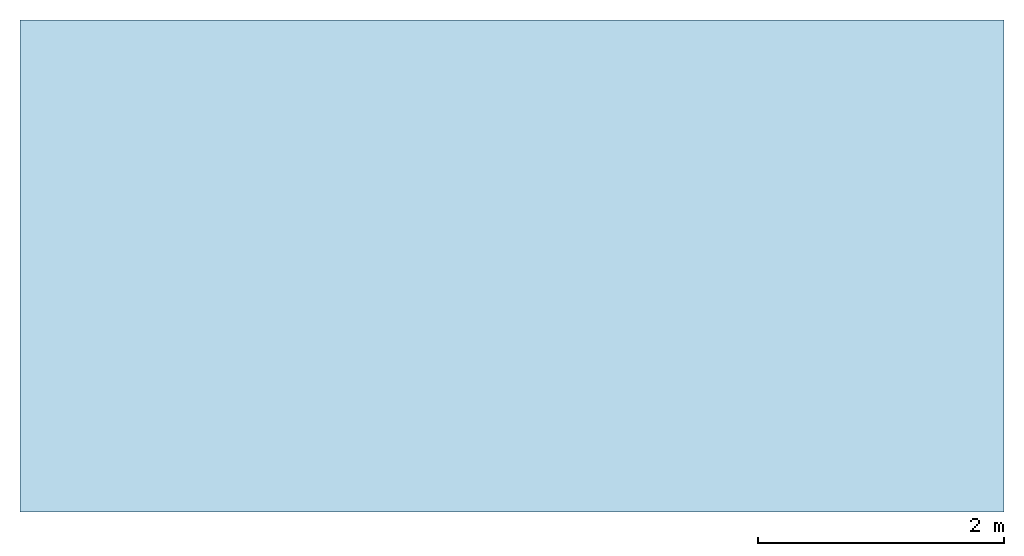
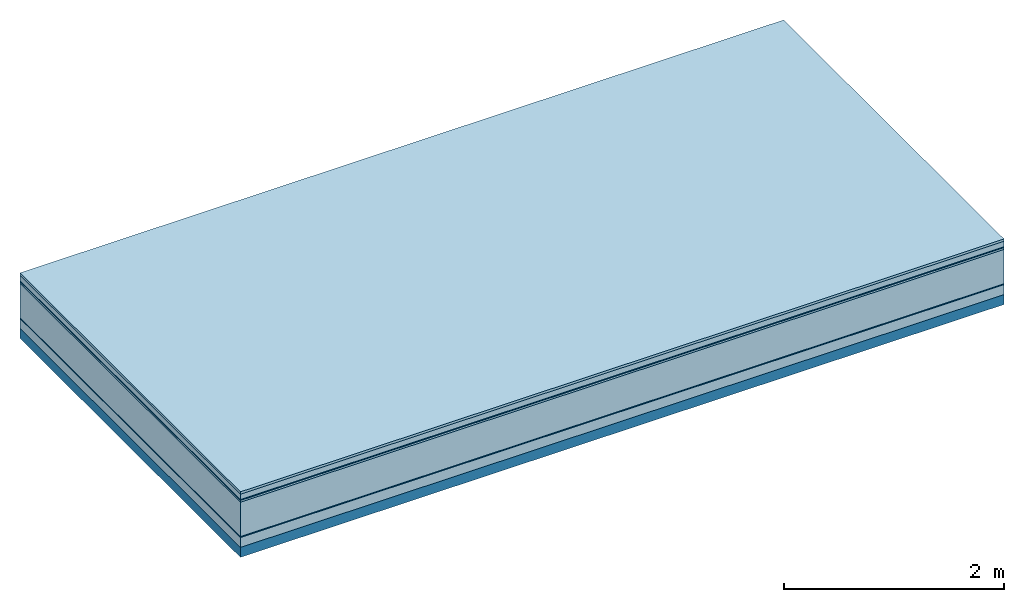
# One storey: 7 plates, 1 member, 1 element without a shape of its own.
"""IFC4 building model written with IfcOpenShell, lengths in metres."""

from ifc_helpers import new_model, si_unit, derived_unit, direction, frame, frame_2d, origin, origin_with_axes, place, context, project, spatial, rectangle, extrude, material, layer, layer_set, type_object, element, aggregate, save


model = new_model("IFC4")

# Units and contexts
plan_context = context("Plan", 3, precision=1e-05, world=origin(), true_north=direction((0.0, 1.0)))
model_context = context("Model", 3, precision=1e-05, world=origin(), true_north=direction((0.0, 1.0)))
ifc_project = project(units=[si_unit("LENGTHUNIT", "METRE"), derived_unit("SOUNDPRESSUREUNIT", [(si_unit("PRESSUREUNIT", "PASCAL", prefix="MICRO"), 0)]), si_unit("ENERGYUNIT", "JOULE", prefix="MEGA"), si_unit("MASSUNIT", "GRAM", prefix="KILO"), derived_unit("THERMALTRANSMITTANCEUNIT", [(si_unit("POWERUNIT", "WATT"), 1), (si_unit("AREAUNIT", "SQUARE_METRE"), -1), (si_unit("THERMODYNAMICTEMPERATUREUNIT", "KELVIN"), -1)]), derived_unit("AREADENSITYUNIT", [(si_unit("MASSUNIT", "GRAM", prefix="KILO"), 1), (si_unit("AREAUNIT", "SQUARE_METRE"), -1)]), derived_unit("USERDEFINED", [(si_unit("ENERGYUNIT", "JOULE", prefix="MEGA"), 1), (si_unit("AREAUNIT", "SQUARE_METRE"), -1)])], contexts=[plan_context, model_context])

# Site, building, storey
site = spatial("IfcSite", under=ifc_project)
building_placement = place(None, origin())
building = spatial("IfcBuilding", under=site, at=building_placement)
storey_placement = place(building_placement, origin())
storey = spatial("IfcBuildingStorey", under=building, at=storey_placement)

# Slab, member, plates
ifc_material_1 = material(Category="07.009")
ifc_layer_1 = layer(ifc_material_1, 0.026, Name="Use and protection layer 3")
ifc_material_2 = material(Category="07.011")
ifc_layer_2 = layer(ifc_material_2, 0.06, Name="Use and protection layer 2")
ifc_material_3 = material(Name="Protective layer + Fire protection cover RF1", Category="09.007")
ifc_layer_3 = layer(ifc_material_3, 0.01, Name="Use and protection layer 1")
ifc_material_4 = material(Name="Bituminous", Category="09.003")
ifc_layer_4 = layer(ifc_material_4, 0.02, Name="Seal")
ifc_material_5 = material(Name="Mineral wool", Category="10.008")
ifc_layer_5 = layer(ifc_material_5, 0.38, Name="Exterior insulation layer 1")
ifc_material_6 = material(Name="Vapor-permeable barrier", Category="09.006")
ifc_layer_6 = layer(ifc_material_6, 0.01, Name="layer / temporary roof")
ifc_material_7 = material(Category="01.002")
ifc_layer_7 = layer(ifc_material_7, 0.11, Name="above 1st layer")
ifc_material_8 = material(Name="Rigid, of the art")
ifc_layer_8 = layer(ifc_material_8, 0.0, Name="Bond")
ifc_layer_9 = layer(None, 0.11, Name="Support")
ifc_layer_set = layer_set([ifc_layer_1, ifc_layer_2, ifc_layer_3, ifc_layer_4, ifc_layer_5, ifc_layer_6, ifc_layer_7, ifc_layer_8, ifc_layer_9])
slab_type = type_object("IfcSlabType", Name="F0082", PredefinedType="NOTDEFINED", material=ifc_layer_set)
slab_placement = place(None, frame((0.0, 0.0, 0.0), z_axis=(0.0, 0.0, -1.0), x_axis=(1.0, 0.0, 0.0)))
slab = element("IfcSlab", 1, at=slab_placement, inside=storey, type_object=slab_type, material=ifc_layer_set, Name="Slab #1")
ifc_material_9 = material(Name="Solid timber panel")
member_placement = place(slab_placement, origin())
member = element("IfcMember", 2, at=member_placement, material=ifc_material_9, Name="Support", context=plan_context, shape_type="SweptSolid", body=[
    extrude(rectangle(XDim=1.0, YDim=0.11, at=frame_2d((0.5, 0.055), x_axis=(1.0, 0.0))), frame((0.0, 4.0, 0.616), z_axis=(0.0, -1.0, 0.0), x_axis=(1.0, 0.0, 0.0)), (0.0, 0.0, 1.0), 4.0),
    extrude(rectangle(XDim=1.0, YDim=0.11, at=frame_2d((0.5, 0.055), x_axis=(1.0, 0.0))), frame((1.0, 4.0, 0.616), z_axis=(0.0, -1.0, 0.0), x_axis=(1.0, 0.0, 0.0)), (0.0, 0.0, 1.0), 4.0),
    extrude(rectangle(XDim=1.0, YDim=0.11, at=frame_2d((0.5, 0.055), x_axis=(1.0, 0.0))), frame((2.0, 4.0, 0.616), z_axis=(0.0, -1.0, 0.0), x_axis=(1.0, 0.0, 0.0)), (0.0, 0.0, 1.0), 4.0),
    extrude(rectangle(XDim=1.0, YDim=0.11, at=frame_2d((0.5, 0.055), x_axis=(1.0, 0.0))), frame((3.0, 4.0, 0.616), z_axis=(0.0, -1.0, 0.0), x_axis=(1.0, 0.0, 0.0)), (0.0, 0.0, 1.0), 4.0),
    extrude(rectangle(XDim=1.0, YDim=0.11, at=frame_2d((0.5, 0.055), x_axis=(1.0, 0.0))), frame((4.0, 4.0, 0.616), z_axis=(0.0, -1.0, 0.0), x_axis=(1.0, 0.0, 0.0)), (0.0, 0.0, 1.0), 4.0),
    extrude(rectangle(XDim=1.0, YDim=0.11, at=frame_2d((0.5, 0.055), x_axis=(1.0, 0.0))), frame((5.0, 4.0, 0.616), z_axis=(0.0, -1.0, 0.0), x_axis=(1.0, 0.0, 0.0)), (0.0, 0.0, 1.0), 4.0),
    extrude(rectangle(XDim=1.0, YDim=0.11, at=frame_2d((0.5, 0.055), x_axis=(1.0, 0.0))), frame((6.0, 4.0, 0.616), z_axis=(0.0, -1.0, 0.0), x_axis=(1.0, 0.0, 0.0)), (0.0, 0.0, 1.0), 4.0),
    extrude(rectangle(XDim=1.0, YDim=0.11, at=frame_2d((0.5, 0.055), x_axis=(1.0, 0.0))), frame((7.0, 4.0, 0.616), z_axis=(0.0, -1.0, 0.0), x_axis=(1.0, 0.0, 0.0)), (0.0, 0.0, 1.0), 4.0),
])
plate_1_placement = place(slab_placement, origin())
plate_1 = element("IfcPlate", 3, at=plate_1_placement, material=ifc_material_1, Name="Use and protection layer 3", context=plan_context, shape_type="SweptSolid", body=[
    extrude(rectangle(XDim=8.0, YDim=4.0, at=frame_2d((4.0, 2.0), x_axis=(1.0, 0.0))), origin_with_axes(), (0.0, 0.0, 1.0), 0.026),
])
plate_2_placement = place(slab_placement, origin())
plate_2 = element("IfcPlate", 4, at=plate_2_placement, material=ifc_material_2, Name="Use and protection layer 2", context=plan_context, shape_type="SweptSolid", body=[
    extrude(rectangle(XDim=8.0, YDim=4.0, at=frame_2d((4.0, 2.0), x_axis=(1.0, 0.0))), frame((0.0, 0.0, 0.026), z_axis=(0.0, 0.0, 1.0), x_axis=(1.0, 0.0, 0.0)), (0.0, 0.0, 1.0), 0.06),
])
plate_3_placement = place(slab_placement, origin())
plate_3 = element("IfcPlate", 5, at=plate_3_placement, material=ifc_material_3, Name="Use and protection layer 1", context=plan_context, shape_type="SweptSolid", body=[
    extrude(rectangle(XDim=8.0, YDim=4.0, at=frame_2d((4.0, 2.0), x_axis=(1.0, 0.0))), frame((0.0, 0.0, 0.086), z_axis=(0.0, 0.0, 1.0), x_axis=(1.0, 0.0, 0.0)), (0.0, 0.0, 1.0), 0.01),
])
plate_4_placement = place(slab_placement, origin())
plate_4 = element("IfcPlate", 6, at=plate_4_placement, material=ifc_material_4, Name="Seal", context=plan_context, shape_type="SweptSolid", body=[
    extrude(rectangle(XDim=8.0, YDim=4.0, at=frame_2d((4.0, 2.0), x_axis=(1.0, 0.0))), frame((0.0, 0.0, 0.096), z_axis=(0.0, 0.0, 1.0), x_axis=(1.0, 0.0, 0.0)), (0.0, 0.0, 1.0), 0.02),
])
plate_5_placement = place(slab_placement, origin())
plate_5 = element("IfcPlate", 7, at=plate_5_placement, material=ifc_material_5, Name="Exterior insulation layer 1", context=plan_context, shape_type="SweptSolid", body=[
    extrude(rectangle(XDim=8.0, YDim=4.0, at=frame_2d((4.0, 2.0), x_axis=(1.0, 0.0))), frame((0.0, 0.0, 0.116), z_axis=(0.0, 0.0, 1.0), x_axis=(1.0, 0.0, 0.0)), (0.0, 0.0, 1.0), 0.38),
])
plate_6_placement = place(slab_placement, origin())
plate_6 = element("IfcPlate", 8, at=plate_6_placement, material=ifc_material_6, Name="layer / temporary roof", context=plan_context, shape_type="SweptSolid", body=[
    extrude(rectangle(XDim=8.0, YDim=4.0, at=frame_2d((4.0, 2.0), x_axis=(1.0, 0.0))), frame((0.0, 0.0, 0.496), z_axis=(0.0, 0.0, 1.0), x_axis=(1.0, 0.0, 0.0)), (0.0, 0.0, 1.0), 0.01),
])
plate_7_placement = place(slab_placement, origin())
plate_7 = element("IfcPlate", 9, at=plate_7_placement, material=ifc_material_7, Name="above 1st layer", context=plan_context, shape_type="SweptSolid", body=[
    extrude(rectangle(XDim=8.0, YDim=4.0, at=frame_2d((4.0, 2.0), x_axis=(1.0, 0.0))), frame((0.0, 0.0, 0.506), z_axis=(0.0, 0.0, 1.0), x_axis=(1.0, 0.0, 0.0)), (0.0, 0.0, 1.0), 0.11),
])
aggregate(slab, [plate_1, plate_2, plate_3, plate_4, plate_5, plate_6, plate_7, member])

save(model, "model.ifc")
